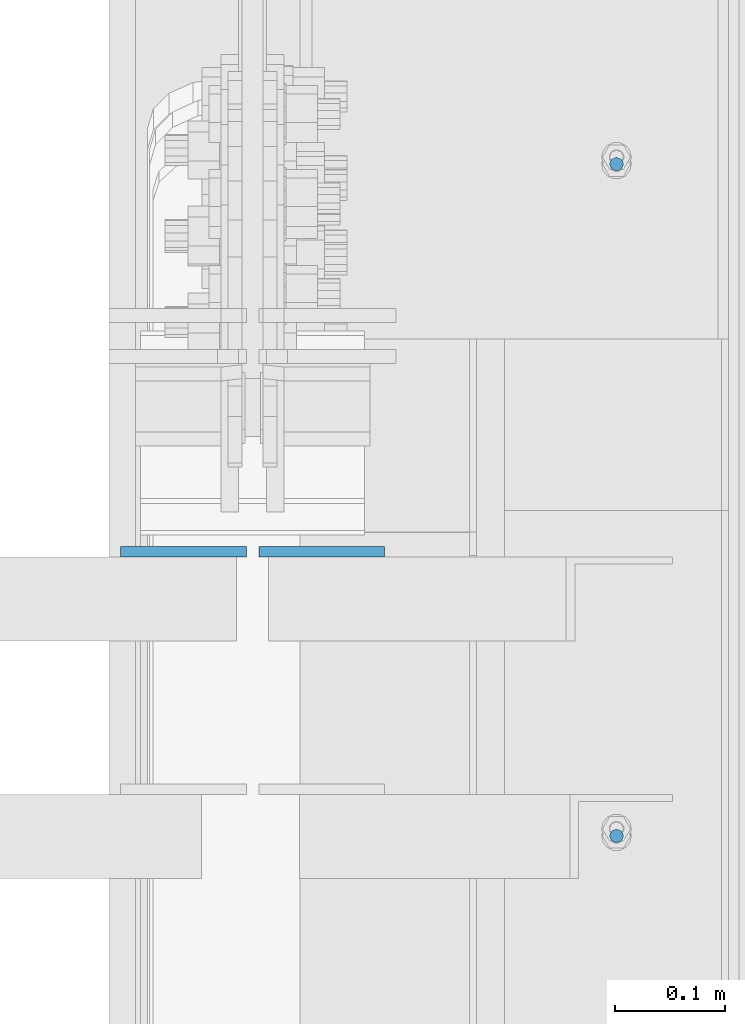
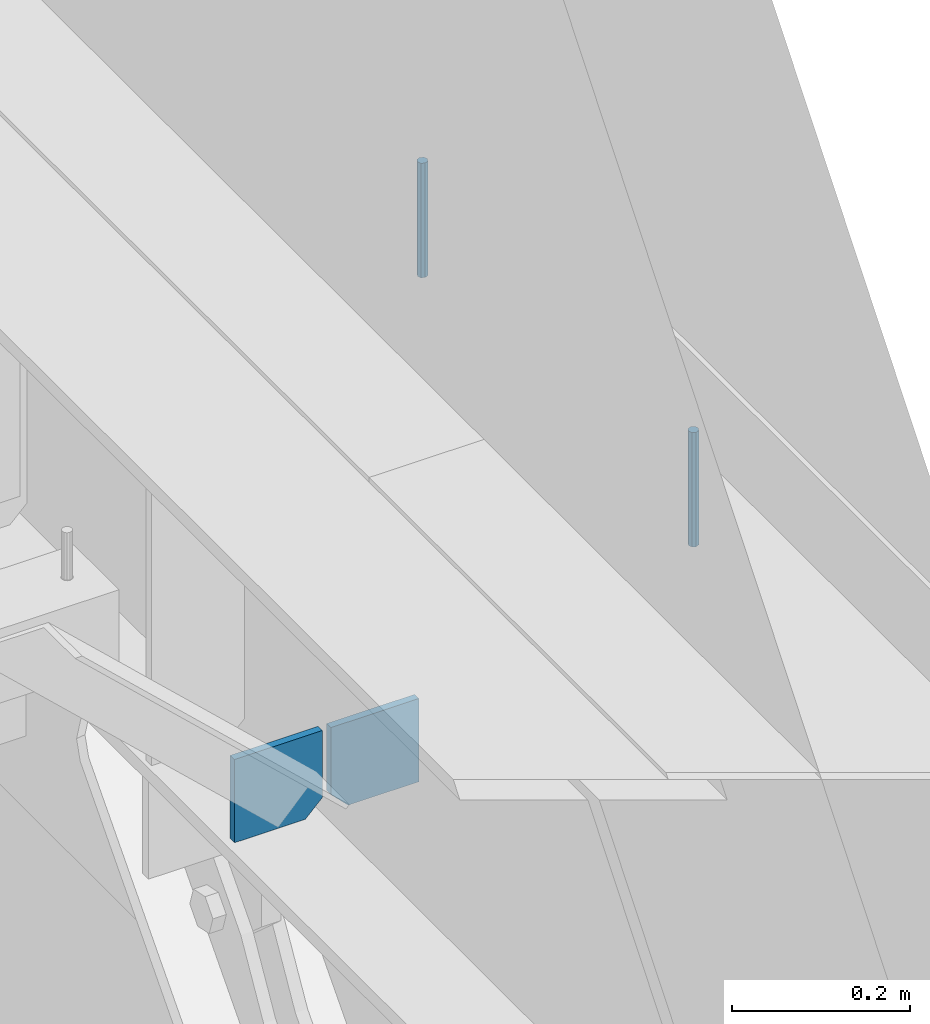
# One storey, part 474 of 1179: 4 columns, 1 element without a shape of its own.
"""IFC2X3 building model written with IfcOpenShell, lengths in millimetres."""

from ifc_helpers import new_model, si_unit, frame, origin_with_axes, place, context, subcontext, project, spatial, faceted_brep, material, type_object, element, aggregate, save


model = new_model("IFC2X3")

# Units and contexts
model_context = context("Model", 3, precision=1e-05, world=origin_with_axes())
body_context = subcontext(model_context, "Body", "Model", "MODEL_VIEW")
ifc_project = project(units=[si_unit("LENGTHUNIT", "METRE", prefix="MILLI"), si_unit("AREAUNIT", "SQUARE_METRE"), si_unit("VOLUMEUNIT", "CUBIC_METRE"), si_unit("MASSUNIT", "GRAM", prefix="KILO"), si_unit("TIMEUNIT", "SECOND"), si_unit("PLANEANGLEUNIT", "RADIAN"), si_unit("SOLIDANGLEUNIT", "STERADIAN"), si_unit("THERMODYNAMICTEMPERATUREUNIT", "DEGREE_CELSIUS"), si_unit("LUMINOUSINTENSITYUNIT", "LUMEN")], contexts=[model_context])

# Site, building, storey
site_placement = place(None, origin_with_axes())
site = spatial("IfcSite", under=ifc_project, at=site_placement, CompositionType="ELEMENT")
building_placement = place(site_placement, origin_with_axes())
building = spatial("IfcBuilding", under=site, at=building_placement, Name="Undefined", CompositionType="ELEMENT")
storey_placement = place(building_placement, origin_with_axes())
storey = spatial("IfcBuildingStorey", under=building, at=storey_placement, Name="Undefined", CompositionType="ELEMENT", Elevation=0.0)

# Assembly, columns
assembly_placement = place(storey_placement, origin_with_axes())
assembly = element("IfcElementAssembly", 1, at=assembly_placement, inside=storey, Name="BEAM", AssemblyPlace="NOTDEFINED", PredefinedType="RIGID_FRAME")
ifc_material_1 = material(Name="STEEL/A36")
column_type_1 = type_object("IfcColumnType", PredefinedType="NOTDEFINED")
column_1_placement = place(assembly_placement, frame((24245.09375, 30064.7541453824, 3702.05), z_axis=(1.0, 0.0, 0.0), x_axis=(0.0, 0.0, 1.0)))
column_1 = element("IfcColumn", 2, at=column_1_placement, type_object=column_type_1, material=ifc_material_1, Name="PLATE", context=body_context, shape_type="Brep", body=[
    faceted_brep([(22.2250000000004, 4.76250000000073, 57.1500000000015), (0.0, 4.76250000000073, 34.9249999999993), (0.0, -4.76250000000073, 34.9249999999993), (22.2250000000004, -4.76250000000073, 57.1500000000015), (114.300000000001, 4.76250000000073, 57.1500000000015), (114.300000000001, 4.76250000000073, -57.1500000000015), (0.0, 4.76250000000073, -57.1500000000015), (114.300000000001, -4.76250000000073, 57.1500000000015), (0.0, -4.76250000000073, -57.1500000000015), (114.300000000001, -4.76250000000073, -57.1500000000015)], [[[0, 1, 2, 3]], [[4, 5, 6, 1, 0]], [[7, 4, 0, 3]], [[8, 9, 7, 3, 2]], [[8, 6, 5, 9]], [[7, 9, 5, 4]], [[6, 8, 2, 1]]]),
])
column_2_placement = place(assembly_placement, frame((24370.50625, 30064.7541453824, 3702.05), z_axis=(-1.0, 0.0, 0.0), x_axis=(0.0, 0.0, 1.0)))
column_2 = element("IfcColumn", 3, at=column_2_placement, type_object=column_type_1, material=ifc_material_1, Name="PLATE", context=body_context, shape_type="Brep", body=[
    faceted_brep([(22.2250000000004, 4.76250000000073, 57.1500000000015), (0.0, 4.76250000000073, 34.9249999999993), (0.0, -4.76250000000073, 34.9249999999993), (22.2250000000004, -4.76250000000073, 57.1500000000015), (114.300000000001, 4.76250000000073, 57.1500000000015), (114.300000000001, 4.76250000000073, -57.1500000000015), (0.0, 4.76250000000073, -57.1500000000015), (114.300000000001, -4.76250000000073, 57.1500000000015), (0.0, -4.76250000000073, -57.1500000000015), (114.300000000001, -4.76250000000073, -57.1500000000015)], [[[0, 1, 2, 3]], [[4, 5, 6, 1, 0]], [[7, 4, 0, 3]], [[8, 9, 7, 3, 2]], [[8, 6, 5, 9]], [[7, 9, 5, 4]], [[6, 8, 2, 1]]]),
])
ifc_material_2 = material(Name="STEEL/A307")
column_type_2 = type_object("IfcColumnType", PredefinedType="NOTDEFINED")
column_3_placement = place(assembly_placement, frame((24638.0, 30416.50025, 4108.45), z_axis=(0.0, 1.0, 0.0), x_axis=(0.0, 0.0, 1.0)))
column_3 = element("IfcColumn", 4, at=column_3_placement, type_object=column_type_2, material=ifc_material_2, Name="THREADED ROD", context=body_context, shape_type="Brep", body=[
    faceted_brep([(0.0, -6.34999999999854, 0.0), (0.0, -4.49012806053361, -4.49012806053452), (157.162499999999, -4.49012806053361, -4.49012806053361), (157.162499999999, -6.34999999999854, 0.0), (0.0, 0.0, -6.34999999999991), (157.162499999999, 0.0, -6.34999999999854), (0.0, 4.49012806053361, -4.49012806053452), (157.162499999999, 4.49012806053361, -4.49012806053361), (0.0, 6.34999999999854, 0.0), (157.162499999999, 6.34999999999854, 0.0), (0.0, 4.49012806053361, 4.49012806053452), (157.162499999999, 4.49012806053361, 4.49012806053361), (0.0, 0.0, 6.34999999999991), (157.162499999999, 0.0, 6.34999999999854), (0.0, -4.49012806053361, 4.49012806053452), (157.162499999999, -4.49012806053361, 4.49012806053361)], [[[0, 1, 2, 3]], [[1, 4, 5, 2]], [[4, 6, 7, 5]], [[6, 8, 9, 7]], [[8, 10, 11, 9]], [[10, 12, 13, 11]], [[12, 14, 15, 13]], [[14, 0, 3, 15]], [[5, 7, 9, 11, 13, 15, 3, 2]], [[14, 12, 10, 8, 6, 4, 1, 0]]]),
])
column_4_placement = place(assembly_placement, frame((24638.0, 29806.90025, 4108.45), z_axis=(0.0, 1.0, 0.0), x_axis=(0.0, 0.0, 1.0)))
column_4 = element("IfcColumn", 5, at=column_4_placement, type_object=column_type_2, material=ifc_material_2, Name="THREADED ROD", context=body_context, shape_type="Brep", body=[
    faceted_brep([(0.0, -6.34999999999854, 0.0), (0.0, -4.49012806053361, -4.49012806053452), (157.162499999999, -4.49012806053361, -4.49012806053361), (157.162499999999, -6.34999999999854, 0.0), (0.0, 0.0, -6.34999999999991), (157.162499999999, 0.0, -6.34999999999854), (0.0, 4.49012806053361, -4.49012806053452), (157.162499999999, 4.49012806053361, -4.49012806053361), (0.0, 6.34999999999854, 0.0), (157.162499999999, 6.34999999999854, 0.0), (0.0, 4.49012806053361, 4.49012806053452), (157.162499999999, 4.49012806053361, 4.49012806053361), (0.0, 0.0, 6.34999999999991), (157.162499999999, 0.0, 6.34999999999854), (0.0, -4.49012806053361, 4.49012806053452), (157.162499999999, -4.49012806053361, 4.49012806053361)], [[[0, 1, 2, 3]], [[1, 4, 5, 2]], [[4, 6, 7, 5]], [[6, 8, 9, 7]], [[8, 10, 11, 9]], [[10, 12, 13, 11]], [[12, 14, 15, 13]], [[14, 0, 3, 15]], [[5, 7, 9, 11, 13, 15, 3, 2]], [[14, 12, 10, 8, 6, 4, 1, 0]]]),
])
aggregate(assembly, [column_3, column_4, column_1, column_2])

save(model, "model.ifc")
